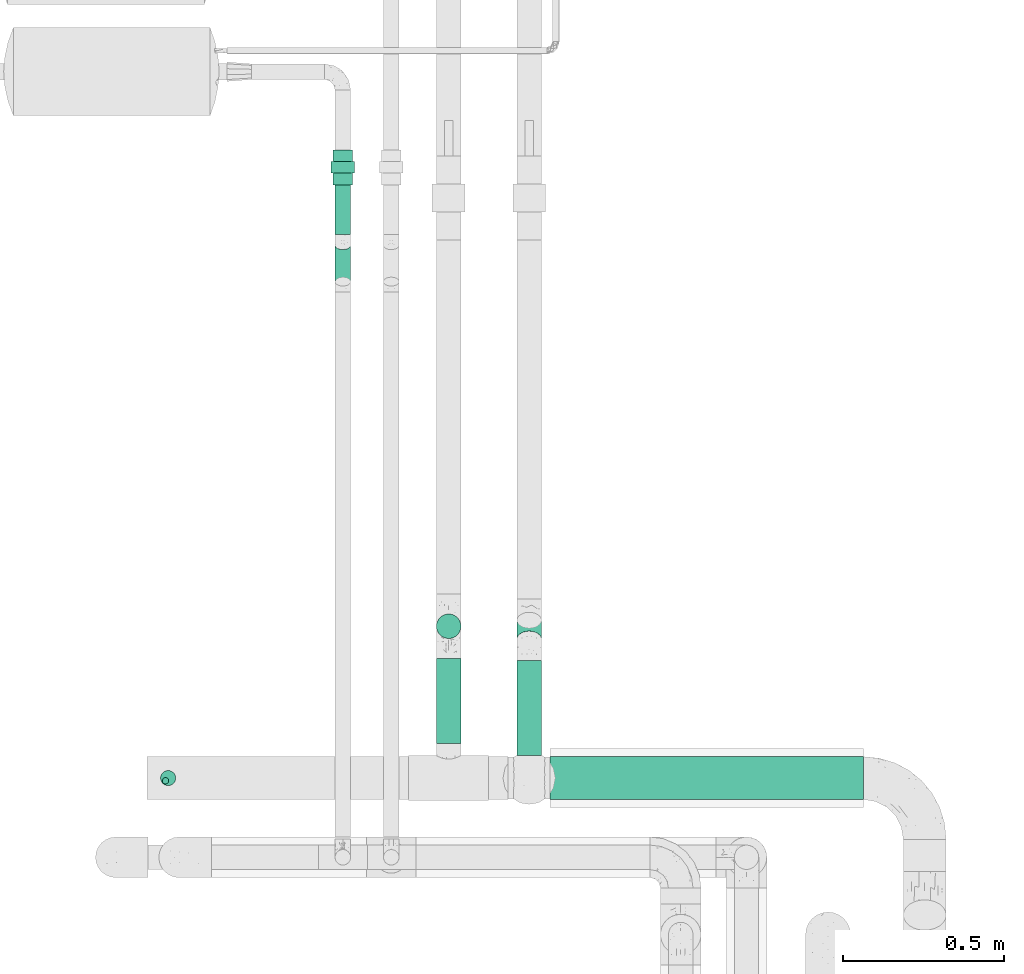
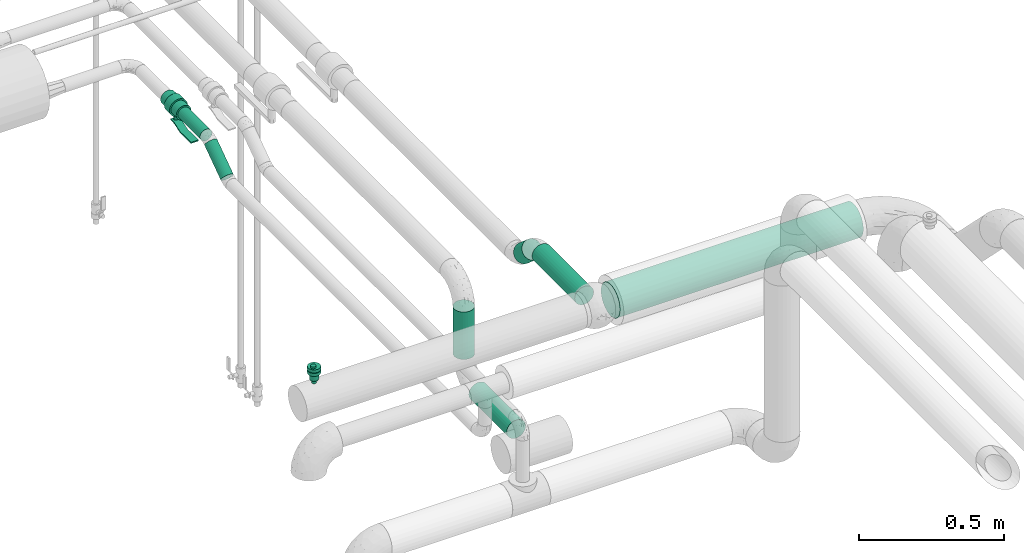
# One storey, part 562 of 827: 7 flow segments, 2 flow controllers.
"""IFC2X3 building model written with IfcOpenShell, lengths in millimetres."""

from ifc_helpers import new_model, entity, si_unit, converted_unit, derived_unit, direction, frame, origin, origin_2d_with_axis, place, context, subcontext, project, spatial, polyline, circle, outline, extrude, faceted_brep, source, transform, mapped, material, material_list, type_object, type_shapes, element, save


model = new_model("IFC2X3")

# Units and contexts
model_context = context("Model", 3, precision=0.01, world=origin(), true_north=direction((6.12303176911189e-17, 1.0)))
body_context = subcontext(model_context, "Body", "Model", "MODEL_VIEW")
ifc_project = project(units=[si_unit("LENGTHUNIT", "METRE", prefix="MILLI"), si_unit("AREAUNIT", "SQUARE_METRE"), si_unit("VOLUMEUNIT", "CUBIC_METRE"), converted_unit("PLANEANGLEUNIT", "DEGREE", entity("IfcRatioMeasure", 0.0174532925199433), si_unit("PLANEANGLEUNIT", "RADIAN"), dimensions=[0, 0, 0, 0, 0, 0, 0]), si_unit("MASSUNIT", "GRAM", prefix="KILO"), derived_unit("MASSDENSITYUNIT", [(si_unit("MASSUNIT", "GRAM", prefix="KILO"), 1), (si_unit("LENGTHUNIT", "METRE"), -3)]), derived_unit("MOMENTOFINERTIAUNIT", [(si_unit("LENGTHUNIT", "METRE"), 4)]), si_unit("TIMEUNIT", "SECOND"), si_unit("FREQUENCYUNIT", "HERTZ"), si_unit("THERMODYNAMICTEMPERATUREUNIT", "DEGREE_CELSIUS"), derived_unit("THERMALTRANSMITTANCEUNIT", [(si_unit("MASSUNIT", "GRAM", prefix="KILO"), 1), (si_unit("THERMODYNAMICTEMPERATUREUNIT", "KELVIN"), -1), (si_unit("TIMEUNIT", "SECOND"), -3)]), derived_unit("VOLUMETRICFLOWRATEUNIT", [(si_unit("LENGTHUNIT", "METRE"), 3), (si_unit("TIMEUNIT", "SECOND"), -1)]), derived_unit("MASSFLOWRATEUNIT", [(si_unit("MASSUNIT", "GRAM", prefix="KILO"), 1), (si_unit("TIMEUNIT", "SECOND"), -1)]), derived_unit("ROTATIONALFREQUENCYUNIT", [(si_unit("TIMEUNIT", "SECOND"), -1)]), si_unit("ELECTRICCURRENTUNIT", "AMPERE"), si_unit("ELECTRICVOLTAGEUNIT", "VOLT"), si_unit("POWERUNIT", "WATT"), si_unit("FORCEUNIT", "NEWTON", prefix="KILO"), si_unit("ILLUMINANCEUNIT", "LUX"), si_unit("LUMINOUSFLUXUNIT", "LUMEN"), si_unit("LUMINOUSINTENSITYUNIT", "CANDELA"), derived_unit("USERDEFINED", [(si_unit("MASSUNIT", "GRAM", prefix="KILO"), -1), (si_unit("LENGTHUNIT", "METRE"), -2), (si_unit("TIMEUNIT", "SECOND"), 3), (si_unit("LUMINOUSFLUXUNIT", "LUMEN"), 1)]), derived_unit("LINEARVELOCITYUNIT", [(si_unit("LENGTHUNIT", "METRE"), 1), (si_unit("TIMEUNIT", "SECOND"), -1)]), si_unit("PRESSUREUNIT", "PASCAL"), derived_unit("USERDEFINED", [(si_unit("LENGTHUNIT", "METRE"), -2), (si_unit("MASSUNIT", "GRAM", prefix="KILO"), 1), (si_unit("TIMEUNIT", "SECOND"), -2)]), derived_unit("LINEARFORCEUNIT", [(si_unit("MASSUNIT", "GRAM", prefix="KILO"), 1), (si_unit("LENGTHUNIT", "METRE"), 1), (si_unit("TIMEUNIT", "SECOND"), -2), (si_unit("LENGTHUNIT", "METRE"), -1)]), derived_unit("PLANARFORCEUNIT", [(si_unit("MASSUNIT", "GRAM", prefix="KILO"), 1), (si_unit("LENGTHUNIT", "METRE"), 1), (si_unit("TIMEUNIT", "SECOND"), -2), (si_unit("LENGTHUNIT", "METRE"), -2)])], contexts=[model_context])

# Site, building, storey
site_placement = place(None, origin())
site = spatial("IfcSite", under=ifc_project, at=site_placement, CompositionType="ELEMENT")
building_placement = place(site_placement, origin())
building = spatial("IfcBuilding", under=site, at=building_placement, CompositionType="ELEMENT")
storey_placement = place(building_placement, frame((0.0, 0.0, 28200.0)))
storey = spatial("IfcBuildingStorey", under=building, at=storey_placement, Name="08", CompositionType="ELEMENT", Elevation=28200.0)

# Flow segments
pipe_segment_type_1 = type_object("IfcPipeSegmentType", PredefinedType="NOTDEFINED")
flow_segment_1_placement = place(storey_placement, frame((25904.69, 12746.7, 2700.0)))
element("IfcFlowSegment", 1, at=flow_segment_1_placement, inside=storey, type_object=pipe_segment_type_1, context=body_context, shape_type="SweptSolid", body=[
    extrude(circle(Radius=38.0, at=origin_2d_with_axis()), frame((39.6, 39.6, 0.0)), (0.0, 0.0, 1.0), 200.000000000011),
])
flow_segment_2_placement = place(storey_placement, frame((25904.58, 12423.55, 2560.4)))
element("IfcFlowSegment", 2, at=flow_segment_2_placement, inside=storey, type_object=pipe_segment_type_1, context=body_context, shape_type="SweptSolid", body=[
    extrude(circle(Radius=38.0, at=origin_2d_with_axis()), frame((39.6, 0.02, 39.6), z_axis=(0.000436744503642467, 0.999999904627115, 0.0), x_axis=(0.999999904627115, -0.000436744503642467, 0.0)), (0.0, 0.0, 1.0), 262.731246177695),
])
flow_segment_3_placement = place(storey_placement, frame((26154.31, 12719.65, 2994.25)))
element("IfcFlowSegment", 3, at=flow_segment_3_placement, inside=storey, type_object=pipe_segment_type_1, context=body_context, shape_type="SweptSolid", body=[
    extrude(circle(Radius=38.0, at=origin_2d_with_axis()), frame((39.6, 26.53, 81.22), z_axis=(0.0, 0.754709580222645, -0.656059028990654), x_axis=(-1.0, 0.0, 0.0)), (0.0, 0.0, 1.0), 77.6483741906666),
])
flow_segment_4_placement = place(storey_placement, frame((26154.31, 12385.57, 3060.4)))
element("IfcFlowSegment", 4, at=flow_segment_4_placement, inside=storey, type_object=pipe_segment_type_1, context=body_context, shape_type="SweptSolid", body=[
    extrude(circle(Radius=38.0, at=origin_2d_with_axis()), frame((39.6, 0.0, 39.6), z_axis=(0.0, 1.0, 0.0), x_axis=(-1.0, 0.0, 0.0)), (0.0, 0.0, 1.0), 295.006008045202),
])
flow_segment_5_placement = place(storey_placement, frame((26258.91, 12247.47, 3031.9)))
element("IfcFlowSegment", 5, at=flow_segment_5_placement, inside=storey, type_object=pipe_segment_type_1, context=body_context, shape_type="SweptSolid", body=[
    extrude(circle(Radius=66.5, at=origin_2d_with_axis()), frame((0.0, 68.1, 68.1), z_axis=(1.0, 0.0, 0.0), x_axis=(0.0, -1.0, 0.0)), (0.0, 0.0, 1.0), 971.124054571153),
])
pipe_segment_type_2 = type_object("IfcPipeSegmentType", PredefinedType="NOTDEFINED")
flow_segment_6_placement = place(storey_placement, frame((25590.58, 14000.49, 2974.4)))
element("IfcFlowSegment", 6, at=flow_segment_6_placement, inside=storey, type_object=pipe_segment_type_2, context=body_context, shape_type="SweptSolid", body=[
    extrude(circle(Radius=24.0, at=origin_2d_with_axis()), frame((25.6, 0.0, 25.6), z_axis=(0.0, 1.0, 0.0), x_axis=(-1.0, 0.0, 0.0)), (0.0, 0.0, 1.0), 154.495464956261),
])
flow_segment_7_placement = place(storey_placement, frame((25590.58, 13839.35, 2889.1)))
element("IfcFlowSegment", 7, at=flow_segment_7_placement, inside=storey, type_object=pipe_segment_type_2, context=body_context, shape_type="SweptSolid", body=[
    extrude(circle(Radius=24.0, at=origin_2d_with_axis()), frame((25.6, 15.38, 21.24), z_axis=(0.0, 0.818556692462271, 0.574425749096632), x_axis=(-1.0, 0.0, 0.0)), (0.0, 0.0, 1.0), 138.077833498019),
])

# Flow controllers
ifc_material = material()
ifc_material_list = material_list([ifc_material, ifc_material, ifc_material, ifc_material, ifc_material])
valve_type_1 = type_object("IfcValveType", PredefinedType="NOTDEFINED", material=ifc_material_list)
shared_shape_1 = source(origin(), body_context, "Body", "SweptSolid", [
    extrude(circle(Radius=30.0, at=origin_2d_with_axis()), frame((-54.0, 0.0, 0.0), z_axis=(1.0, 0.0, 0.0), x_axis=(0.0, 1.0, 0.0)), (0.0, 0.0, 1.0), 36.0),
    extrude(circle(Radius=36.0, at=origin_2d_with_axis()), frame((-18.0, 0.0, 0.0), z_axis=(1.0, 0.0, 0.0), x_axis=(0.0, 1.0, 0.0)), (0.0, 0.0, 1.0), 36.0),
    extrude(circle(Radius=30.0, at=origin_2d_with_axis()), frame((18.0, 0.0, 0.0), z_axis=(1.0, 0.0, 0.0), x_axis=(0.0, 1.0, 0.0)), (0.0, 0.0, 1.0), 36.0),
    extrude(outline(polyline([(-55.88, -5.0), (-55.88, -10.0), (-35.46, -10.0), (8.04, 5.0), (84.12, 5.0), (84.12, 10.0), (7.21, 10.0), (-36.29, -5.0), (-55.88, -5.0)])), frame((45.88, -15.0, 68.5), z_axis=(0.0, -1.0, 0.0), x_axis=(1.0, 0.0, 0.0)), (0.0, 0.0, -1.0), 30.0),
    extrude(circle(Radius=8.0, at=origin_2d_with_axis()), origin(), (0.0, 0.0, 1.0), 76.0),
])
type_shapes(valve_type_1, [shared_shape_1])
flow_controller_1_placement = place(storey_placement, frame((25616.18, 14208.99, 3000.0), z_axis=(0.0, 0.0, -1.0), x_axis=(0.0, -1.0, 0.0)))
element("IfcFlowController", 8, at=flow_controller_1_placement, inside=storey, type_object=valve_type_1, material=ifc_material_list, context=body_context, shape_type="MappedRepresentation", body=[
    mapped(shared_shape_1, transform((0.0, 0.0, 0.0), scale=1.0)),
])
valve_type_2 = type_object("IfcValveType", PredefinedType="NOTDEFINED", material=ifc_material)
shared_shape_2 = source(origin(), body_context, "Body", "Brep", [
    faceted_brep([(-6.86, -13.27, -15.58), (-5.66, -12.77, -15.58), (-5.66, -12.77, -13.2), (-6.86, -13.27, -13.2), (-6.86, -13.27, -0.5), (-5.66, -12.77, -0.5), (-5.66, -12.77, 2.49), (-6.86, -13.27, 2.49), (-8.16, -13.44, -15.58), (-8.16, -13.44, -13.2), (-8.16, -13.44, -0.5), (-8.16, -13.44, 2.49), (-3.83, -10.94, -15.58), (-3.33, -9.74, -15.58), (-3.33, -9.74, -13.2), (-3.83, -10.94, -13.2), (-3.83, -10.94, -0.5), (-3.33, -9.74, -0.5), (-3.33, -9.74, 2.49), (-3.83, -10.94, 2.49), (-4.62, -11.98, -15.58), (-4.62, -11.98, -13.2), (-4.62, -11.98, -0.5), (-4.62, -11.98, 2.49), (-3.16, -8.44, -13.2), (-3.16, -8.44, -15.58), (-3.16, -8.44, 2.49), (-3.16, -8.44, -0.5), (-3.83, -5.94, -15.58), (-4.62, -4.91, -15.58), (-4.62, -4.91, -13.2), (-3.83, -5.94, -13.2), (-3.83, -5.94, -0.5), (-4.62, -4.91, -0.5), (-4.62, -4.91, 2.49), (-3.83, -5.94, 2.49), (-3.33, -7.15, -15.58), (-3.33, -7.15, -13.2), (-3.33, -7.15, -0.5), (-3.33, -7.15, 2.49), (-6.86, -3.61, -15.58), (-8.16, -3.44, -15.58), (-8.16, -3.44, -13.2), (-6.86, -3.61, -13.2), (-6.86, -3.61, -0.5), (-8.16, -3.44, -0.5), (-8.16, -3.44, 2.49), (-6.86, -3.61, 2.49), (-5.66, -4.11, -15.58), (-5.66, -4.11, -13.2), (-5.66, -4.11, -0.5), (-5.66, -4.11, 2.49), (-9.45, -3.61, -0.5), (-9.45, -3.61, 2.49), (-9.45, -3.61, -15.58), (-9.45, -3.61, -13.2), (-10.66, -4.11, -0.5), (-10.66, -4.11, 2.49), (-10.66, -4.11, -15.58), (-10.66, -4.11, -13.2), (-12.49, -5.94, 2.49), (-11.69, -4.91, 2.49), (-11.69, -4.91, -0.5), (-12.49, -5.94, -0.5), (-11.69, -4.91, -15.58), (-12.49, -5.94, -15.58), (-12.49, -5.94, -13.2), (-11.69, -4.91, -13.2), (-12.99, -7.15, 2.49), (-12.99, -7.15, -0.5), (-12.99, -7.15, -15.58), (-12.99, -7.15, -13.2), (-13.16, -8.44, 2.49), (-13.16, -8.44, -0.5), (-13.16, -8.44, -13.2), (-13.16, -8.44, -15.58), (-12.49, -10.94, -0.5), (-12.49, -10.94, 2.49), (-12.99, -9.74, 2.49), (-12.99, -9.74, -0.5), (-12.99, -9.74, -15.58), (-12.49, -10.94, -15.58), (-12.49, -10.94, -13.2), (-12.99, -9.74, -13.2), (-11.69, -11.98, -0.5), (-11.69, -11.98, 2.49), (-11.69, -11.98, -15.58), (-11.69, -11.98, -13.2), (-9.45, -13.27, 2.49), (-10.66, -12.77, 2.49), (-10.66, -12.77, -0.5), (-9.45, -13.27, -0.5), (-10.66, -12.77, -15.58), (-9.45, -13.27, -15.58), (-9.45, -13.27, -13.2), (-10.66, -12.77, -13.2), (6.08, -22.7, -0.5), (0.0, -23.5, -0.5), (11.75, -20.35, -0.5), (16.62, -16.62, -0.5), (20.35, -11.75, -0.5), (22.7, -6.08, -0.5), (23.5, 0.0, -0.5), (22.7, 6.08, -0.5), (20.35, 11.75, -0.5), (16.62, 16.62, -0.5), (11.75, 20.35, -0.5), (6.08, 22.7, -0.5), (0.0, 23.5, -0.5), (-6.08, 22.7, -0.5), (-11.75, 20.35, -0.5), (-16.62, 16.62, -0.5), (-20.35, 11.75, -0.5), (-22.7, 6.08, -0.5), (-23.5, 0.0, -0.5), (-22.7, -6.08, -0.5), (-20.35, -11.75, -0.5), (-16.62, -16.62, -0.5), (-11.75, -20.35, -0.5), (-6.08, -22.7, -0.5), (11.75, 20.35, -13.2), (6.08, 22.7, -13.2), (16.62, 16.62, -13.2), (20.35, 11.75, -13.2), (22.7, 6.08, -13.2), (23.5, 0.0, -13.2), (22.7, -6.08, -13.2), (20.35, -11.75, -13.2), (16.62, -16.62, -13.2), (11.75, -20.35, -13.2), (6.08, -22.7, -13.2), (0.0, -23.5, -13.2), (-6.08, -22.7, -13.2), (-11.75, -20.35, -13.2), (-16.62, -16.62, -13.2), (-20.35, -11.75, -13.2), (-22.7, -6.08, -13.2), (-23.5, 0.0, -13.2), (-22.7, 6.08, -13.2), (-20.35, 11.75, -13.2), (-16.62, 16.62, -13.2), (-11.75, 20.35, -13.2), (-6.08, 22.7, -13.2), (0.0, 23.5, -13.2), (-22.7, -6.08, -28.28), (-22.7, -6.08, -15.58), (-23.5, 0.0, -15.58), (-23.5, 0.0, -28.28), (-20.35, -11.75, -28.28), (-20.35, -11.75, -15.58), (-11.75, -20.35, -15.58), (-16.62, -16.62, -15.58), (-16.62, -16.62, -28.28), (-11.75, -20.35, -28.28), (-6.08, -22.7, -15.58), (-6.08, -22.7, -28.28), (0.0, -23.5, -15.58), (0.0, -23.5, -28.28), (6.08, -22.7, -28.28), (6.08, -22.7, -15.58), (11.75, -20.35, -28.28), (11.75, -20.35, -15.58), (20.35, -11.75, -15.58), (16.62, -16.62, -15.58), (16.62, -16.62, -28.28), (20.35, -11.75, -28.28), (22.7, -6.08, -15.58), (22.7, -6.08, -28.28), (23.5, 0.0, -15.58), (23.5, 0.0, -28.28), (22.7, 6.08, -28.28), (22.7, 6.08, -15.58), (20.35, 11.75, -28.28), (20.35, 11.75, -15.58), (11.75, 20.35, -15.58), (16.62, 16.62, -15.58), (16.62, 16.62, -28.28), (11.75, 20.35, -28.28), (6.08, 22.7, -15.58), (6.08, 22.7, -28.28), (0.0, 23.5, -15.58), (0.0, 23.5, -28.28), (-6.08, 22.7, -28.28), (-6.08, 22.7, -15.58), (-11.75, 20.35, -28.28), (-11.75, 20.35, -15.58), (-20.35, 11.75, -15.58), (-16.62, 16.62, -15.58), (-16.62, 16.62, -28.28), (-20.35, 11.75, -28.28), (-22.7, 6.08, -15.58), (-22.7, 6.08, -28.28), (8.23, 14.25, -28.28), (4.26, 15.89, -28.28), (11.63, 11.63, -28.28), (14.25, 8.22, -28.28), (15.89, 4.26, -28.28), (16.45, 0.0, -28.28), (15.89, -4.26, -28.28), (14.25, -8.23, -28.28), (11.63, -11.63, -28.28), (8.23, -14.25, -28.28), (4.26, -15.89, -28.28), (0.0, -16.45, -28.28), (-4.26, -15.89, -28.28), (-8.22, -14.25, -28.28), (-11.63, -11.63, -28.28), (-14.25, -8.23, -28.28), (-15.89, -4.26, -28.28), (-16.45, 0.0, -28.28), (-15.89, 4.26, -28.28), (-14.25, 8.22, -28.28), (-11.63, 11.63, -28.28), (-8.22, 14.25, -28.28), (-4.26, 15.89, -28.28), (0.0, 16.45, -28.28), (-15.89, -4.26, -52.7), (-16.45, 0.0, -52.7), (-14.25, -8.23, -52.7), (-11.63, -11.63, -52.7), (-8.22, -14.25, -52.7), (-4.26, -15.89, -52.7), (0.0, -16.45, -52.7), (4.26, -15.89, -52.7), (8.23, -14.25, -52.7), (11.63, -11.63, -52.7), (14.25, -8.23, -52.7), (15.89, -4.26, -52.7), (16.45, 0.0, -52.7), (15.89, 4.26, -52.7), (14.25, 8.22, -52.7), (11.63, 11.63, -52.7), (8.23, 14.25, -52.7), (4.26, 15.89, -52.7), (0.0, 16.45, -52.7), (-4.26, 15.89, -52.7), (-8.22, 14.25, -52.7), (-11.63, 11.63, -52.7), (-14.25, 8.22, -52.7), (-15.89, 4.26, -52.7), (10.61, 9.36, -56.39), (8.29, 11.45, -56.39), (9.98, 12.23, -54.94), (-13.58, 4.48, -56.31), (-14.89, 5.25, -54.94), (-12.77, 8.5, -55.51), (6.32, 14.92, -54.11), (-3.39, 14.2, -56.13), (-6.26, 13.77, -55.71), (-2.15, 15.69, -54.85), (2.15, 15.59, -55.0), (10.54, 4.37, -56.8), (12.15, 6.9, -56.46), (14.89, 5.25, -54.94), (13.8, 0.0, -56.2), (13.58, 4.48, -56.31), (12.77, 8.5, -55.51), (15.25, 0.0, -55.6), (-9.98, 12.23, -54.94), (6.26, 13.77, -55.71), (4.37, 10.54, -56.8), (3.28, 13.85, -56.34), (-15.25, 0.0, -55.6), (-6.32, 14.92, -54.11), (-10.54, 4.37, -56.8), (-12.35, 0.0, -56.8), (-12.15, 6.9, -56.46), (-10.61, 9.36, -56.39), (8.73, 8.73, -56.8), (-4.37, 10.54, -56.8), (-6.55, 9.64, -56.8), (-13.8, 0.0, -56.2), (-0.21, 14.49, -56.2), (0.0, 12.35, -56.8), (-8.73, 8.73, -56.8), (-8.29, 11.45, -56.39), (12.35, 0.0, -56.8), (-10.61, -9.36, -56.39), (-8.29, -11.45, -56.39), (-9.98, -12.23, -54.94), (13.58, -4.48, -56.31), (14.89, -5.25, -54.94), (12.77, -8.5, -55.51), (-6.32, -14.92, -54.11), (6.32, -14.92, -54.11), (9.98, -12.23, -54.94), (-2.15, -15.59, -55.0), (-10.54, -4.37, -56.8), (-12.15, -6.9, -56.46), (-12.77, -8.5, -55.51), (2.15, -15.69, -54.85), (-14.89, -5.25, -54.94), (-13.58, -4.48, -56.31), (-8.73, -8.73, -56.8), (6.26, -13.77, -55.71), (4.37, -10.54, -56.8), (6.55, -9.64, -56.8), (12.15, -6.9, -56.46), (10.61, -9.36, -56.39), (10.54, -4.37, -56.8), (-6.26, -13.77, -55.71), (-4.37, -10.54, -56.8), (-3.28, -13.85, -56.34), (3.39, -14.2, -56.13), (0.21, -14.49, -56.2), (0.0, -12.35, -56.8), (8.73, -8.73, -56.8), (8.29, -11.45, -56.39), (-7.94, 2.13, -56.8), (-8.22, 0.0, -56.8), (-7.12, 4.11, -56.8), (-7.94, -2.13, -56.8), (-7.12, -4.11, -56.8), (-5.82, -5.82, -56.8), (-4.11, -7.12, -56.8), (-2.13, -7.94, -56.8), (0.0, -8.23, -56.8), (2.13, -7.94, -56.8), (4.11, -7.12, -56.8), (5.82, -5.82, -56.8), (7.12, -4.11, -56.8), (7.94, -2.13, -56.8), (8.23, 0.0, -56.8), (7.94, 2.13, -56.8), (7.12, 4.11, -56.8), (5.82, 5.82, -56.8), (4.11, 7.12, -56.8), (2.13, 7.94, -56.8), (0.0, 8.22, -56.8), (-2.13, 7.94, -56.8), (-4.11, 7.12, -56.8), (-5.82, 5.82, -56.8), (0.0, 8.22, -70.0), (2.13, 7.94, -70.0), (4.11, 7.12, -70.0), (5.82, 5.82, -70.0), (7.12, 4.11, -70.0), (7.94, 2.13, -70.0), (8.23, 0.0, -70.0), (7.94, -2.13, -70.0), (7.12, -4.11, -70.0), (5.82, -5.82, -70.0), (4.11, -7.12, -70.0), (2.13, -7.94, -70.0), (0.0, -8.23, -70.0), (-2.13, -7.94, -70.0), (-4.11, -7.12, -70.0), (-5.82, -5.82, -70.0), (-7.12, -4.11, -70.0), (-7.94, -2.13, -70.0), (-8.22, 0.0, -70.0), (-7.94, 2.13, -70.0), (-7.12, 4.11, -70.0), (-5.82, 5.82, -70.0), (-4.11, 7.12, -70.0), (-2.13, 7.94, -70.0), (1.25, -5.8, 9.33), (0.27, -3.45, 9.33), (-1.28, -1.43, 9.33), (-3.3, 0.12, 9.33), (-5.65, 1.09, 9.33), (-8.17, 1.43, 9.33), (-10.69, 1.09, 9.33), (-13.05, 0.12, 9.33), (-15.07, -1.43, 9.33), (-16.61, -3.45, 9.33), (-17.59, -5.8, 9.33), (-17.92, -8.32, 9.33), (-17.59, -10.85, 9.33), (-16.61, -13.2, 9.33), (-15.07, -15.22, 9.33), (-13.05, -16.77, 9.33), (-10.69, -17.74, 9.33), (-8.17, -18.07, 9.33), (-5.65, -17.74, 9.33), (-3.3, -16.77, 9.33), (-1.28, -15.22, 9.33), (0.27, -13.2, 9.33), (1.25, -10.85, 9.33), (1.58, -8.32, 9.33), (-16.61, -3.45, 2.49), (-17.59, -5.8, 2.49), (-15.07, -1.43, 2.49), (-13.05, 0.12, 2.49), (-10.69, 1.09, 2.49), (-8.17, 1.43, 2.49), (-5.65, 1.09, 2.49), (-3.3, 0.12, 2.49), (-1.28, -1.43, 2.49), (0.27, -3.45, 2.49), (1.25, -5.8, 2.49), (1.58, -8.32, 2.49), (1.25, -10.85, 2.49), (0.27, -13.2, 2.49), (-1.28, -15.22, 2.49), (-3.3, -16.77, 2.49), (-5.65, -17.74, 2.49), (-8.17, -18.07, 2.49), (-10.69, -17.74, 2.49), (-13.05, -16.77, 2.49), (-15.07, -15.22, 2.49), (-16.61, -13.2, 2.49), (-17.59, -10.85, 2.49), (-17.92, -8.32, 2.49)], [[[0, 1, 2, 3]], [[4, 5, 6, 7]], [[8, 0, 3, 9]], [[10, 4, 7, 11]], [[12, 13, 14, 15]], [[16, 17, 18, 19]], [[20, 12, 15, 21]], [[22, 16, 19, 23]], [[1, 20, 21, 2]], [[5, 22, 23, 6]], [[24, 14, 13, 25]], [[26, 18, 17, 27]], [[28, 29, 30, 31]], [[32, 33, 34, 35]], [[36, 28, 31, 37]], [[38, 32, 35, 39]], [[40, 41, 42, 43]], [[44, 45, 46, 47]], [[48, 40, 43, 49]], [[50, 44, 47, 51]], [[29, 48, 49, 30]], [[33, 50, 51, 34]], [[36, 37, 24, 25]], [[38, 39, 26, 27]], [[52, 53, 46, 45]], [[41, 54, 55, 42]], [[56, 57, 53, 52]], [[54, 58, 59, 55]], [[60, 61, 62, 63]], [[64, 65, 66, 67]], [[56, 62, 61, 57]], [[58, 64, 67, 59]], [[68, 60, 63, 69]], [[65, 70, 71, 66]], [[72, 68, 69, 73]], [[74, 71, 70, 75]], [[76, 77, 78, 79]], [[80, 81, 82, 83]], [[84, 85, 77, 76]], [[81, 86, 87, 82]], [[88, 89, 90, 91]], [[92, 93, 94, 95]], [[84, 90, 89, 85]], [[86, 92, 95, 87]], [[11, 88, 91, 10]], [[93, 8, 9, 94]], [[79, 78, 72, 73]], [[80, 83, 74, 75]], [[96, 16, 97]], [[16, 96, 17]], [[98, 17, 96]], [[27, 17, 98]], [[98, 99, 27]], [[100, 27, 99]], [[100, 38, 27]], [[38, 100, 101]], [[38, 101, 102]], [[38, 102, 32]], [[32, 102, 103]], [[104, 32, 103]], [[104, 33, 32]], [[104, 105, 33]], [[105, 106, 33]], [[106, 50, 33]], [[50, 106, 107]], [[50, 107, 108]], [[108, 44, 50]], [[44, 108, 109]], [[44, 109, 110]], [[110, 45, 44]], [[45, 110, 111]], [[45, 111, 112]], [[52, 45, 112]], [[52, 112, 113]], [[56, 52, 113]], [[113, 114, 56]], [[114, 62, 56]], [[62, 114, 63]], [[114, 115, 63]], [[115, 69, 63]], [[73, 69, 115]], [[115, 116, 73]], [[116, 79, 73]], [[79, 116, 76]], [[76, 116, 117]], [[76, 117, 84]], [[117, 90, 84]], [[118, 90, 117]], [[90, 118, 91]], [[10, 91, 118]], [[10, 118, 119]], [[97, 5, 119]], [[119, 5, 4]], [[10, 119, 4]], [[22, 97, 16]], [[22, 5, 97]], [[120, 49, 121]], [[49, 120, 30]], [[122, 30, 120]], [[122, 123, 30]], [[30, 123, 31]], [[123, 124, 31]], [[31, 124, 125]], [[37, 31, 125]], [[37, 125, 126]], [[127, 37, 126]], [[37, 127, 24]], [[127, 128, 24]], [[129, 24, 128]], [[14, 24, 129]], [[129, 130, 14]], [[130, 15, 14]], [[130, 131, 15]], [[131, 21, 15]], [[2, 21, 131]], [[2, 131, 132]], [[2, 132, 3]], [[3, 132, 9]], [[132, 133, 9]], [[94, 9, 133]], [[133, 95, 94]], [[95, 133, 134]], [[95, 134, 87]], [[82, 87, 134]], [[135, 82, 134]], [[135, 83, 82]], [[74, 83, 135]], [[135, 136, 74]], [[74, 136, 71]], [[71, 136, 66]], [[66, 136, 137]], [[137, 67, 66]], [[67, 137, 59]], [[137, 138, 59]], [[59, 138, 55]], [[139, 55, 138]], [[55, 139, 42]], [[140, 42, 139]], [[141, 42, 140]], [[42, 141, 43]], [[141, 142, 43]], [[43, 142, 143]], [[121, 49, 143]], [[43, 143, 49]], [[136, 115, 114, 137]], [[144, 145, 146, 147]], [[135, 116, 115, 136]], [[148, 149, 145, 144]], [[118, 117, 134, 133]], [[150, 151, 152, 153]], [[135, 134, 117, 116]], [[148, 152, 151, 149]], [[119, 118, 133, 132]], [[154, 150, 153, 155]], [[97, 119, 132, 131]], [[156, 154, 155, 157]], [[130, 96, 97, 131]], [[158, 159, 156, 157]], [[129, 98, 96, 130]], [[160, 161, 159, 158]], [[100, 99, 128, 127]], [[162, 163, 164, 165]], [[129, 128, 99, 98]], [[160, 164, 163, 161]], [[101, 100, 127, 126]], [[166, 162, 165, 167]], [[102, 101, 126, 125]], [[168, 166, 167, 169]], [[124, 103, 102, 125]], [[170, 171, 168, 169]], [[123, 104, 103, 124]], [[172, 173, 171, 170]], [[106, 105, 122, 120]], [[174, 175, 176, 177]], [[123, 122, 105, 104]], [[172, 176, 175, 173]], [[107, 106, 120, 121]], [[178, 174, 177, 179]], [[108, 107, 121, 143]], [[180, 178, 179, 181]], [[142, 109, 108, 143]], [[182, 183, 180, 181]], [[141, 110, 109, 142]], [[184, 185, 183, 182]], [[112, 111, 140, 139]], [[186, 187, 188, 189]], [[141, 140, 111, 110]], [[184, 188, 187, 185]], [[113, 112, 139, 138]], [[190, 186, 189, 191]], [[114, 113, 138, 137]], [[146, 190, 191, 147]], [[159, 12, 156]], [[12, 159, 13]], [[161, 13, 159]], [[25, 13, 161]], [[161, 163, 25]], [[162, 25, 163]], [[162, 36, 25]], [[36, 162, 166]], [[36, 166, 168]], [[36, 168, 28]], [[28, 168, 171]], [[173, 28, 171]], [[173, 29, 28]], [[173, 175, 29]], [[175, 174, 29]], [[174, 48, 29]], [[48, 174, 178]], [[48, 178, 180]], [[180, 40, 48]], [[40, 180, 183]], [[40, 183, 185]], [[185, 41, 40]], [[41, 185, 187]], [[41, 187, 186]], [[54, 41, 186]], [[54, 186, 190]], [[58, 54, 190]], [[190, 146, 58]], [[146, 64, 58]], [[64, 146, 65]], [[146, 145, 65]], [[145, 70, 65]], [[75, 70, 145]], [[145, 149, 75]], [[149, 80, 75]], [[80, 149, 81]], [[81, 149, 151]], [[81, 151, 86]], [[151, 92, 86]], [[150, 92, 151]], [[92, 150, 93]], [[8, 93, 150]], [[8, 150, 154]], [[156, 1, 154]], [[154, 1, 0]], [[8, 154, 0]], [[20, 156, 12]], [[20, 1, 156]], [[177, 176, 192]], [[177, 192, 193]], [[193, 179, 177]], [[192, 176, 194]], [[172, 194, 176]], [[195, 194, 172]], [[196, 195, 172]], [[196, 172, 170]], [[196, 170, 197]], [[197, 170, 169]], [[198, 197, 169]], [[198, 169, 167]], [[199, 198, 167]], [[199, 167, 165]], [[200, 199, 165]], [[165, 164, 200]], [[164, 201, 200]], [[201, 164, 160]], [[201, 160, 202]], [[158, 202, 160]], [[202, 158, 203]], [[203, 158, 157]], [[157, 204, 203]], [[204, 157, 155]], [[204, 155, 205]], [[153, 205, 155]], [[153, 206, 205]], [[153, 152, 206]], [[207, 206, 152]], [[148, 207, 152]], [[144, 207, 148]], [[208, 207, 144]], [[208, 144, 147]], [[147, 209, 208]], [[191, 209, 147]], [[191, 210, 209]], [[210, 191, 189]], [[211, 210, 189]], [[211, 189, 188]], [[211, 188, 212]], [[188, 184, 212]], [[212, 184, 213]], [[213, 184, 182]], [[182, 214, 213]], [[181, 214, 182]], [[179, 215, 181]], [[214, 181, 215]], [[179, 193, 215]], [[216, 208, 209, 217]], [[218, 207, 208, 216]], [[205, 206, 219, 220]], [[218, 219, 206, 207]], [[204, 205, 220, 221]], [[221, 222, 203, 204]], [[202, 223, 224, 201]], [[225, 200, 201, 224]], [[199, 226, 227, 198]], [[225, 226, 199, 200]], [[198, 227, 228, 197]], [[223, 202, 203, 222]], [[229, 196, 197, 228]], [[230, 195, 196, 229]], [[192, 194, 231, 232]], [[230, 231, 194, 195]], [[193, 192, 232, 233]], [[193, 233, 234, 215]], [[214, 235, 236, 213]], [[237, 212, 213, 236]], [[211, 238, 239, 210]], [[237, 238, 211, 212]], [[210, 239, 217, 209]], [[235, 214, 215, 234]], [[240, 241, 242]], [[243, 244, 245]], [[246, 233, 232]], [[247, 248, 249]], [[233, 246, 250]], [[251, 240, 252]], [[253, 254, 255]], [[231, 256, 242]], [[229, 257, 253]], [[228, 257, 229]], [[230, 253, 256]], [[253, 255, 256]], [[229, 253, 230]], [[236, 258, 237]], [[242, 232, 231]], [[259, 260, 261]], [[249, 234, 250]], [[262, 239, 244]], [[230, 256, 231]], [[235, 263, 236]], [[244, 239, 238]], [[243, 264, 265]], [[263, 258, 236]], [[241, 260, 259]], [[234, 249, 235]], [[245, 244, 238]], [[233, 250, 234]], [[258, 245, 237]], [[266, 267, 264]], [[238, 237, 245]], [[240, 251, 268]], [[248, 269, 270]], [[262, 217, 239]], [[243, 271, 244]], [[246, 242, 259]], [[258, 267, 245]], [[240, 256, 252]], [[240, 242, 256]], [[247, 249, 272]], [[263, 249, 248]], [[273, 272, 261]], [[272, 249, 250]], [[274, 267, 275]], [[270, 274, 275]], [[241, 240, 268]], [[275, 258, 248]], [[264, 267, 274]], [[261, 272, 250]], [[247, 273, 269]], [[259, 261, 250]], [[273, 261, 260]], [[273, 247, 272]], [[269, 248, 247]], [[266, 245, 267]], [[251, 255, 276]], [[254, 253, 257]], [[254, 276, 255]], [[271, 262, 244]], [[243, 265, 271]], [[260, 241, 268]], [[242, 241, 259]], [[258, 275, 267]], [[270, 275, 248]], [[242, 246, 232]], [[250, 246, 259]], [[249, 263, 235]], [[258, 263, 248]], [[256, 255, 252]], [[255, 251, 252]], [[264, 243, 266]], [[243, 245, 266]], [[277, 278, 279]], [[280, 281, 282]], [[283, 221, 220]], [[284, 285, 224]], [[221, 283, 286]], [[287, 277, 288]], [[277, 289, 288]], [[219, 289, 279]], [[290, 222, 286]], [[217, 262, 216]], [[218, 291, 289]], [[291, 292, 289]], [[277, 287, 293]], [[216, 291, 218]], [[279, 220, 219]], [[294, 295, 296]], [[224, 285, 225]], [[257, 227, 281]], [[297, 298, 299]], [[226, 281, 227]], [[226, 225, 282]], [[291, 271, 292]], [[227, 257, 228]], [[226, 282, 281]], [[277, 279, 289]], [[218, 289, 219]], [[300, 301, 302]], [[290, 223, 222]], [[280, 254, 281]], [[223, 284, 224]], [[285, 282, 225]], [[221, 286, 222]], [[278, 301, 300]], [[303, 294, 290]], [[216, 262, 291]], [[285, 298, 282]], [[283, 279, 300]], [[280, 299, 276]], [[303, 290, 304]], [[284, 290, 294]], [[305, 304, 302]], [[304, 290, 286]], [[306, 298, 307]], [[296, 306, 307]], [[278, 277, 293]], [[307, 285, 294]], [[299, 298, 306]], [[302, 304, 286]], [[303, 305, 295]], [[300, 302, 286]], [[305, 302, 301]], [[305, 303, 304]], [[295, 294, 303]], [[297, 282, 298]], [[287, 292, 265]], [[271, 291, 262]], [[271, 265, 292]], [[254, 257, 281]], [[280, 276, 254]], [[301, 278, 293]], [[279, 278, 300]], [[285, 307, 298]], [[296, 307, 294]], [[279, 283, 220]], [[286, 283, 300]], [[290, 284, 223]], [[285, 284, 294]], [[289, 292, 288]], [[292, 287, 288]], [[299, 280, 297]], [[280, 282, 297]], [[308, 309, 265]], [[308, 265, 264]], [[308, 264, 274]], [[310, 308, 274]], [[311, 265, 309]], [[311, 287, 265]], [[311, 293, 287]], [[312, 293, 311]], [[312, 313, 293]], [[313, 314, 293]], [[314, 301, 293]], [[314, 305, 301]], [[305, 314, 315]], [[315, 316, 305]], [[316, 317, 305]], [[318, 305, 317]], [[318, 295, 305]], [[318, 296, 295]], [[318, 306, 296]], [[319, 306, 318]], [[320, 306, 319]], [[306, 320, 321]], [[321, 299, 306]], [[321, 276, 299]], [[322, 276, 321]], [[323, 276, 322]], [[323, 251, 276]], [[323, 268, 251]], [[323, 324, 268]], [[324, 325, 268]], [[268, 325, 326]], [[326, 260, 268]], [[326, 273, 260]], [[326, 327, 273]], [[328, 273, 327]], [[328, 329, 273]], [[329, 330, 273]], [[330, 331, 274]], [[330, 274, 270]], [[330, 270, 269]], [[330, 269, 273]], [[310, 274, 331]], [[332, 333, 334, 335, 336, 337, 338, 339, 340, 341, 342, 343, 344, 345, 346, 347, 348, 349, 350, 351, 352, 353, 354, 355]], [[349, 311, 309, 350]], [[348, 312, 311, 349]], [[314, 313, 347, 346]], [[348, 347, 313, 312]], [[315, 314, 346, 345]], [[316, 315, 345, 344]], [[343, 317, 316, 344]], [[342, 318, 317, 343]], [[320, 319, 341, 340]], [[342, 341, 319, 318]], [[321, 320, 340, 339]], [[322, 321, 339, 338]], [[337, 323, 322, 338]], [[336, 324, 323, 337]], [[326, 325, 335, 334]], [[336, 335, 325, 324]], [[327, 326, 334, 333]], [[328, 327, 333, 332]], [[355, 329, 328, 332]], [[354, 330, 329, 355]], [[310, 331, 353, 352]], [[354, 353, 331, 330]], [[308, 310, 352, 351]], [[309, 308, 351, 350]], [[356, 357, 358, 359, 360, 361, 362, 363, 364, 365, 366, 367, 368, 369, 370, 371, 372, 373, 374, 375, 376, 377, 378, 379]], [[380, 60, 381]], [[60, 380, 61]], [[382, 61, 380]], [[61, 382, 57]], [[382, 383, 57]], [[53, 57, 383]], [[384, 53, 383]], [[53, 384, 46]], [[46, 384, 385]], [[386, 46, 385]], [[46, 386, 47]], [[386, 387, 47]], [[51, 47, 387]], [[388, 51, 387]], [[388, 34, 51]], [[388, 389, 34]], [[389, 35, 34]], [[389, 390, 35]], [[39, 35, 390]], [[39, 390, 391]], [[39, 391, 26]], [[392, 26, 391]], [[18, 26, 392]], [[18, 392, 393]], [[19, 18, 393]], [[19, 393, 394]], [[23, 19, 394]], [[394, 395, 23]], [[395, 6, 23]], [[396, 6, 395]], [[396, 7, 6]], [[7, 396, 397]], [[7, 397, 11]], [[11, 397, 88]], [[398, 88, 397]], [[88, 398, 89]], [[89, 398, 399]], [[89, 399, 85]], [[399, 400, 85]], [[85, 400, 77]], [[401, 77, 400]], [[77, 401, 78]], [[402, 78, 401]], [[402, 72, 78]], [[72, 402, 403]], [[403, 381, 68]], [[403, 68, 72]], [[60, 68, 381]], [[396, 374, 373, 397]], [[395, 375, 374, 396]], [[377, 376, 394, 393]], [[395, 394, 376, 375]], [[378, 377, 393, 392]], [[379, 378, 392, 391]], [[390, 356, 379, 391]], [[389, 357, 356, 390]], [[359, 358, 388, 387]], [[389, 388, 358, 357]], [[360, 359, 387, 386]], [[361, 360, 386, 385]], [[384, 362, 361, 385]], [[383, 363, 362, 384]], [[365, 364, 382, 380]], [[383, 382, 364, 363]], [[366, 365, 380, 381]], [[367, 366, 381, 403]], [[402, 368, 367, 403]], [[401, 369, 368, 402]], [[371, 370, 400, 399]], [[401, 400, 370, 369]], [[372, 371, 399, 398]], [[373, 372, 398, 397]]]),
])
type_shapes(valve_type_2, [shared_shape_2])
flow_controller_2_placement = place(storey_placement, frame((25074.6, 12315.57, 3236.5)))
element("IfcFlowController", 9, at=flow_controller_2_placement, inside=storey, type_object=valve_type_2, material=ifc_material, context=body_context, shape_type="MappedRepresentation", body=[
    mapped(shared_shape_2, transform((0.0, 0.0, 0.0), scale=1.0)),
])

save(model, "model.ifc")
